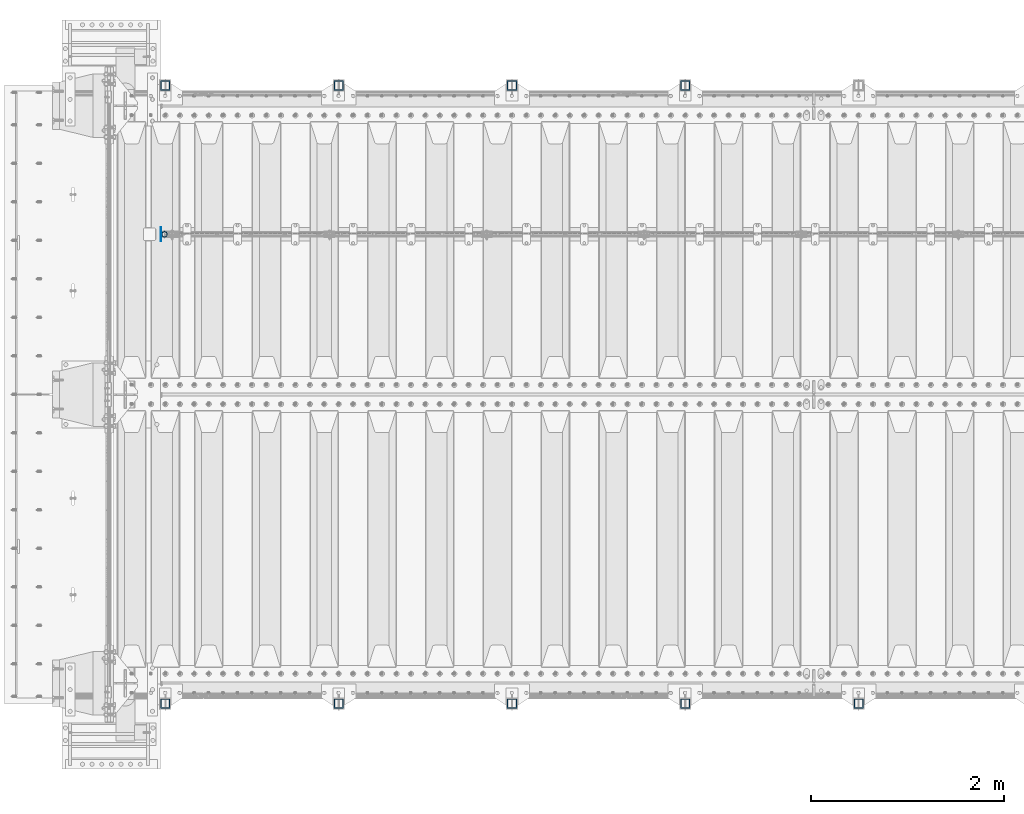
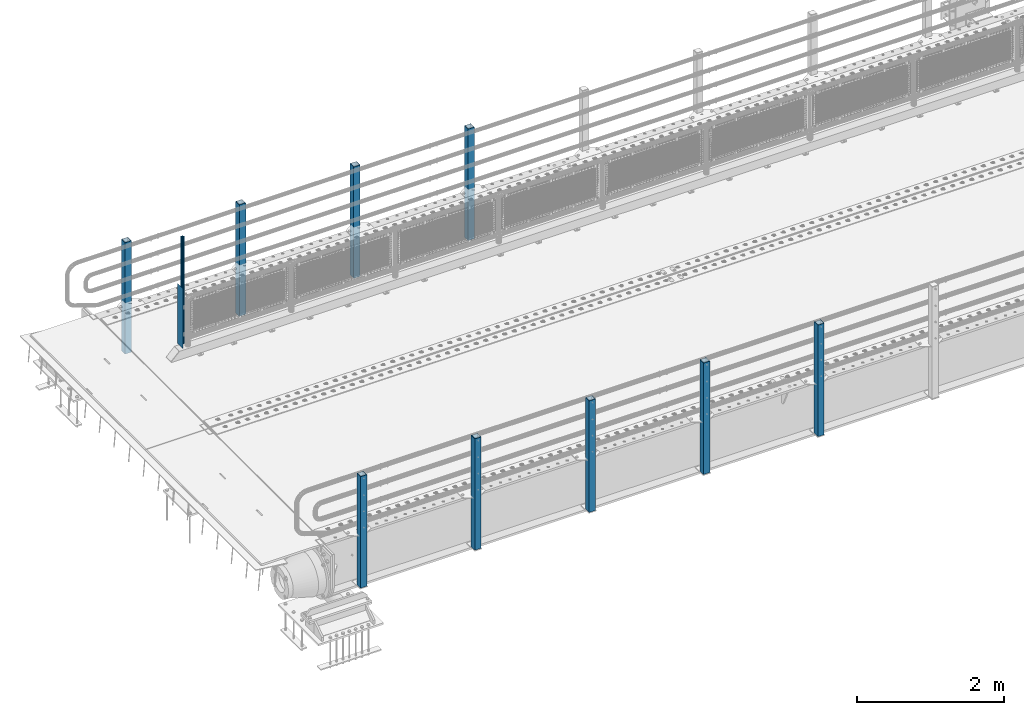
# One storey, part 57 of 242: 11 columns.
"""IFC2X3 building model written with IfcOpenShell, lengths in millimetres."""

from ifc_helpers import new_model, si_unit, frame, origin_with_axes, place, context, subcontext, project, spatial, faceted_brep, material, type_object, element, save


model = new_model("IFC2X3")

# Units and contexts
model_context = context("Model", 3, precision=1e-05, world=origin_with_axes())
body_context = subcontext(model_context, "Body", "Model", "MODEL_VIEW")
ifc_project = project(units=[si_unit("LENGTHUNIT", "METRE", prefix="MILLI"), si_unit("AREAUNIT", "SQUARE_METRE"), si_unit("VOLUMEUNIT", "CUBIC_METRE"), si_unit("MASSUNIT", "GRAM", prefix="KILO"), si_unit("TIMEUNIT", "SECOND"), si_unit("PLANEANGLEUNIT", "RADIAN"), si_unit("SOLIDANGLEUNIT", "STERADIAN"), si_unit("THERMODYNAMICTEMPERATUREUNIT", "DEGREE_CELSIUS"), si_unit("LUMINOUSINTENSITYUNIT", "LUMEN")], contexts=[model_context])

# Site, building, storey
site_placement = place(None, origin_with_axes())
site = spatial("IfcSite", under=ifc_project, at=site_placement, CompositionType="ELEMENT")
building_placement = place(site_placement, origin_with_axes())
building = spatial("IfcBuilding", under=site, at=building_placement, Name="Standard", CompositionType="ELEMENT")
storey_placement = place(building_placement, origin_with_axes())
storey = spatial("IfcBuildingStorey", under=building, at=storey_placement, Name="Undefined", CompositionType="ELEMENT", Elevation=0.0)

# Columns
ifc_material_1 = material(Name="Misc_Undefined")
column_type_1 = type_object("IfcColumnType", PredefinedType="NOTDEFINED")
column_1_placement = place(storey_placement, frame((-41909.0, -19335.5, 238.020000000001), z_axis=(1.0, 0.0, 0.0), x_axis=(0.0, 0.0, 1.0)))
element("IfcColumn", 1, at=column_1_placement, inside=storey, type_object=column_type_1, material=ifc_material_1, context=body_context, shape_type="Brep", body=[
    faceted_brep([(0.0, -25.3499999999985, 0.0), (0.0, -23.4203461491597, 9.70102501045403), (1761.98, -23.4203461491597, 9.70102501045403), (1761.98, -25.3499999999985, 0.0), (0.0, -17.9251569030785, 17.9251569030785), (1761.98, -17.9251569030785, 17.9251569030785), (0.0, -9.70102501045403, 23.4203461491597), (1761.98, -9.70102501045403, 23.4203461491597), (0.0, 0.0, 25.3499999999985), (1761.98, 0.0, 25.3499999999985), (0.0, 9.70102501045403, 23.4203461491597), (1761.98, 9.70102501045403, 23.4203461491597), (0.0, 17.9251569030785, 17.9251569030785), (1761.98, 17.9251569030785, 17.9251569030785), (0.0, 23.4203461491597, 9.70102501045403), (1761.98, 23.4203461491597, 9.70102501045403), (0.0, 25.3499999999985, 0.0), (1761.98, 25.3499999999985, 0.0), (0.0, 23.4203461491597, -9.70102501045403), (1761.98, 23.4203461491597, -9.70102501045403), (0.0, 17.9251569030785, -17.9251569030785), (1761.98, 17.9251569030785, -17.9251569030785), (0.0, 9.70102501045403, -23.4203461491597), (1761.98, 9.70102501045403, -23.4203461491597), (0.0, 0.0, -25.3499999999985), (1761.98, 0.0, -25.3499999999985), (0.0, -9.70102501045403, -23.4203461491597), (1761.98, -9.70102501045403, -23.4203461491597), (0.0, -17.9251569030785, -17.9251569030785), (1761.98, -17.9251569030785, -17.9251569030785), (0.0, -23.4203461491597, -9.70102501045403), (1761.98, -23.4203461491597, -9.70102501045403), (0.0, -30.1500000000015, 0.0), (0.0, -27.8549679052157, -11.5379054858058), (1761.98, -27.8549679052157, -11.5379054858058), (1761.98, -30.1500000000015, 0.0), (0.0, -21.3192694527752, -21.3192694527752), (1761.98, -21.3192694527752, -21.3192694527752), (0.0, -11.5379054858058, -27.8549679052157), (1761.98, -11.5379054858058, -27.8549679052157), (0.0, 0.0, -30.1500000000015), (1761.98, 0.0, -30.1500000000015), (0.0, 11.5379054858058, -27.8549679052157), (1761.98, 11.5379054858058, -27.8549679052157), (0.0, 21.3192694527752, -21.3192694527752), (1761.98, 21.3192694527752, -21.3192694527752), (0.0, 27.8549679052157, -11.5379054858058), (1761.98, 27.8549679052157, -11.5379054858058), (0.0, 30.1500000000015, 0.0), (1761.98, 30.1500000000015, 0.0), (0.0, 27.8549679052157, 11.5379054858058), (1761.98, 27.8549679052157, 11.5379054858058), (0.0, 21.3192694527752, 21.3192694527752), (1761.98, 21.3192694527752, 21.3192694527752), (0.0, 11.5379054858058, 27.8549679052157), (1761.98, 11.5379054858058, 27.8549679052157), (0.0, 0.0, 30.1500000000015), (1761.98, 0.0, 30.1500000000015), (0.0, -11.5379054858058, 27.8549679052157), (1761.98, -11.5379054858058, 27.8549679052157), (0.0, -21.3192694527752, 21.3192694527752), (1761.98, -21.3192694527752, 21.3192694527752), (0.0, -27.8549679052157, 11.5379054858058), (1761.98, -27.8549679052157, 11.5379054858058)], [[[0, 1, 2, 3]], [[1, 4, 5, 2]], [[4, 6, 7, 5]], [[6, 8, 9, 7]], [[8, 10, 11, 9]], [[10, 12, 13, 11]], [[12, 14, 15, 13]], [[14, 16, 17, 15]], [[16, 18, 19, 17]], [[18, 20, 21, 19]], [[20, 22, 23, 21]], [[22, 24, 25, 23]], [[24, 26, 27, 25]], [[26, 28, 29, 27]], [[28, 30, 31, 29]], [[30, 0, 3, 31]], [[32, 33, 34, 35]], [[33, 36, 37, 34]], [[36, 38, 39, 37]], [[38, 40, 41, 39]], [[40, 42, 43, 41]], [[42, 44, 45, 43]], [[44, 46, 47, 45]], [[46, 48, 49, 47]], [[48, 50, 51, 49]], [[50, 52, 53, 51]], [[52, 54, 55, 53]], [[54, 56, 57, 55]], [[56, 58, 59, 57]], [[58, 60, 61, 59]], [[60, 62, 63, 61]], [[62, 32, 35, 63]], [[37, 39, 41, 43, 45, 47, 49, 51, 53, 55, 57, 59, 61, 63, 35, 34], [5, 7, 9, 11, 13, 15, 17, 19, 21, 23, 25, 27, 29, 31, 3, 2]], [[62, 60, 58, 56, 54, 52, 50, 48, 46, 44, 42, 40, 38, 36, 33, 32], [30, 28, 26, 24, 22, 20, 18, 16, 14, 12, 10, 8, 6, 4, 1, 0]]]),
])
column_type_2 = type_object("IfcColumnType", PredefinedType="NOTDEFINED")
column_2_placement = place(storey_placement, frame((-41945.5, -19335.5, 200.0), z_axis=(0.0, 1.0, 0.0), x_axis=(0.0, 0.0, 1.0)))
element("IfcColumn", 2, at=column_2_placement, inside=storey, type_object=column_type_2, material=ifc_material_1, context=body_context, shape_type="Brep", body=[
    faceted_brep([(0.0, 1.5, -75.0), (0.0, 1.5, 75.0), (1000.0, 1.5, 75.0), (1000.0, 1.5, -75.0), (0.0, -1.5, 75.0), (1000.0, -1.5, 75.0), (0.0, -1.5, -75.0), (1000.0, -1.5, -75.0)], [[[0, 1, 2, 3]], [[1, 4, 5, 2]], [[4, 6, 7, 5]], [[6, 0, 3, 7]], [[5, 7, 3, 2]], [[6, 4, 1, 0]]]),
])
ifc_material_2 = material()
column_type_3 = type_object("IfcColumnType", PredefinedType="NOTDEFINED")
for number, where, z_axis, x_axis in (
    (3, (-36499.9999999999, -17789.9999999998, -844.999999999998), (0.0, -1.0, 0.0), (0.0, 0.0, 1.0)),
    (4, (-38299.9999999999, -17789.9999999998, -844.999999999998), (0.0, -1.0, 0.0), (0.0, 0.0, 1.0)),
    (5, (-40099.9999999999, -17789.9999999998, -844.999999999998), (0.0, -1.0, 0.0), (0.0, 0.0, 1.0)),
    (6, (-41899.9999999999, -17789.9999999998, -844.999999999998), (0.0, -1.0, 0.0), (0.0, 0.0, 1.0)),
    (7, (-34700.0000000001, -24210.0000000002, -844.999999999998), (0.0, 1.0, 0.0), (0.0, 0.0, 1.0)),
    (8, (-36500.0000000001, -24210.0000000002, -844.999999999998), (0.0, 1.0, 0.0), (0.0, 0.0, 1.0)),
    (9, (-38300.0000000001, -24210.0000000002, -844.999999999998), (0.0, 1.0, 0.0), (0.0, 0.0, 1.0)),
    (10, (-40100.0000000001, -24210.0000000002, -844.999999999998), (0.0, 1.0, 0.0), (0.0, 0.0, 1.0)),
    (11, (-41900.0000000001, -24210.0000000002, -844.999999999998), (0.0, 1.0, 0.0), (0.0, 0.0, 1.0)),
):
    element("IfcColumn", number, at=place(storey_placement, frame(where, z_axis=z_axis, x_axis=x_axis)), inside=storey, type_object=column_type_3, material=ifc_material_2, context=body_context, shape_type="Brep", body=[
        faceted_brep([(0.0, 40.0, -40.0), (0.0, -40.0, -40.0), (1855.0, -40.0, -40.0), (1855.0, 40.0, -40.0), (0.0, -40.0, 40.0), (1855.0, -40.0, 40.0), (0.0, 40.0, 40.0), (1855.0, 40.0, 40.0), (0.0, 50.0, -50.0), (0.0, 50.0, 50.0), (1855.0, 50.0, 50.0), (1855.0, 50.0, -50.0), (0.0, -50.0, 50.0), (1855.0, -50.0, 50.0), (0.0, -50.0, -50.0), (1855.0, -50.0, -50.0)], [[[0, 1, 2, 3]], [[1, 4, 5, 2]], [[4, 6, 7, 5]], [[6, 0, 3, 7]], [[8, 9, 10, 11]], [[9, 12, 13, 10]], [[12, 14, 15, 13]], [[14, 8, 11, 15]], [[13, 15, 11, 10], [5, 7, 3, 2]], [[14, 12, 9, 8], [6, 4, 1, 0]]]),
    ])

save(model, "model.ifc")
